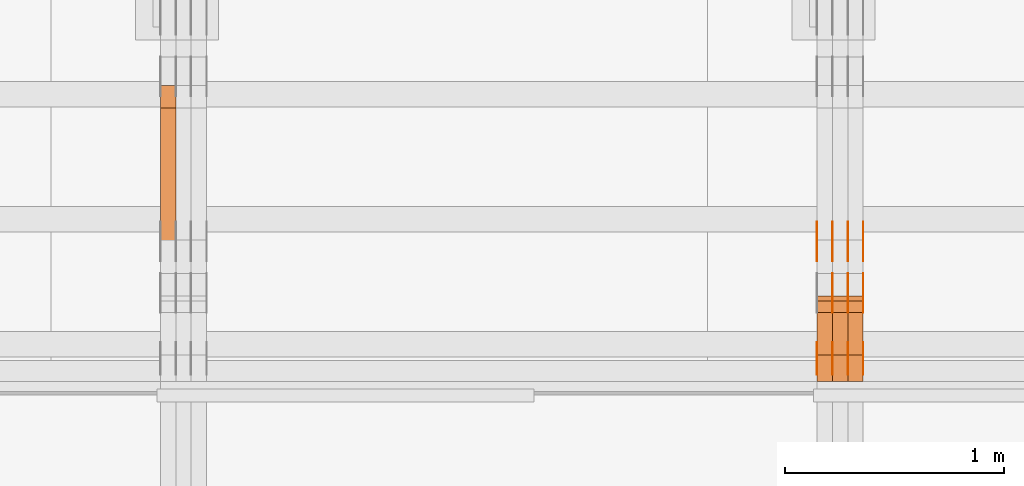
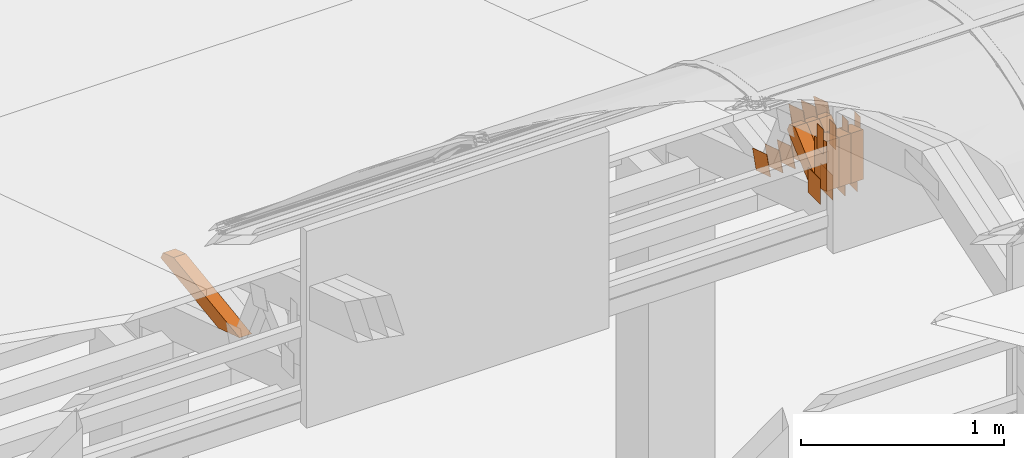
# One storey, part 103 of 385: 30 proxies.
"""IFC2X3 building model written with IfcOpenShell, lengths in millimetres."""

from ifc_helpers import new_model, entity, si_unit, converted_unit, derived_unit, direction, frame, origin, origin_2d_with_axis, place, context, subcontext, project, spatial, polyline, rectangle, outline, extrude, source, transform, mapped, material, type_object, type_shapes, element, save


model = new_model("IFC2X3")

# Units and contexts
model_context = context("Model", 3, precision=0.01, world=origin(), true_north=direction((6.12303176911189e-17, 1.0)))
body_context = subcontext(model_context, "Body", "Model", "MODEL_VIEW")
ifc_project = project(units=[si_unit("LENGTHUNIT", "METRE", prefix="MILLI"), si_unit("AREAUNIT", "SQUARE_METRE"), si_unit("VOLUMEUNIT", "CUBIC_METRE"), converted_unit("PLANEANGLEUNIT", "DEGREE", entity("IfcRatioMeasure", 0.0174532925199433), si_unit("PLANEANGLEUNIT", "RADIAN"), dimensions=[0, 0, 0, 0, 0, 0, 0]), si_unit("MASSUNIT", "GRAM", prefix="KILO"), derived_unit("MASSDENSITYUNIT", [(si_unit("MASSUNIT", "GRAM", prefix="KILO"), 1), (si_unit("LENGTHUNIT", "METRE"), -3)]), si_unit("TIMEUNIT", "SECOND"), si_unit("FREQUENCYUNIT", "HERTZ"), si_unit("THERMODYNAMICTEMPERATUREUNIT", "DEGREE_CELSIUS"), derived_unit("THERMALTRANSMITTANCEUNIT", [(si_unit("MASSUNIT", "GRAM", prefix="KILO"), 1), (si_unit("THERMODYNAMICTEMPERATUREUNIT", "KELVIN"), -1), (si_unit("TIMEUNIT", "SECOND"), -3)]), derived_unit("VOLUMETRICFLOWRATEUNIT", [(si_unit("LENGTHUNIT", "METRE"), 3), (si_unit("TIMEUNIT", "SECOND"), -1)]), si_unit("ELECTRICCURRENTUNIT", "AMPERE"), si_unit("ELECTRICVOLTAGEUNIT", "VOLT"), si_unit("POWERUNIT", "WATT"), si_unit("FORCEUNIT", "NEWTON", prefix="KILO"), si_unit("ILLUMINANCEUNIT", "LUX"), si_unit("LUMINOUSFLUXUNIT", "LUMEN"), si_unit("LUMINOUSINTENSITYUNIT", "CANDELA"), derived_unit("USERDEFINED", [(si_unit("MASSUNIT", "GRAM", prefix="KILO"), -1), (si_unit("LENGTHUNIT", "METRE"), -2), (si_unit("TIMEUNIT", "SECOND"), 3), (si_unit("LUMINOUSFLUXUNIT", "LUMEN"), 1)]), derived_unit("LINEARVELOCITYUNIT", [(si_unit("LENGTHUNIT", "METRE"), 1), (si_unit("TIMEUNIT", "SECOND"), -1)]), si_unit("PRESSUREUNIT", "PASCAL"), derived_unit("USERDEFINED", [(si_unit("LENGTHUNIT", "METRE"), -2), (si_unit("MASSUNIT", "GRAM", prefix="KILO"), 1), (si_unit("TIMEUNIT", "SECOND"), -2)])], contexts=[model_context])

# Site, building, storey
site_placement = place(None, origin())
site = spatial("IfcSite", under=ifc_project, at=site_placement, CompositionType="ELEMENT")
building_placement = place(site_placement, origin())
building = spatial("IfcBuilding", under=site, at=building_placement, CompositionType="ELEMENT")
storey_placement = place(building_placement, origin())
storey = spatial("IfcBuildingStorey", under=building, at=storey_placement, Name="Default", CompositionType="ELEMENT", Elevation=0.0)

# Proxies
ifc_material_1 = material(Name="IfcSurfaceStyle #205378")
building_element_proxy_type_1 = type_object("IfcBuildingElementProxyType", PredefinedType="NOTDEFINED", material=ifc_material_1)
shared_shape_1 = source(origin(), body_context, "Body", "SweptSolid", [
    extrude(rectangle(XDim=150.0, YDim=120.0, at=origin_2d_with_axis()), frame((75.0, 60.0, 0.0), z_axis=(0.0, 0.0, 1.0), x_axis=(-1.0, 0.0, 0.0)), (0.0, 0.0, 1.0), 1.3),
])
type_shapes(building_element_proxy_type_1, [shared_shape_1])
proxy_1_placement = place(building_placement, frame((15386.3, 15840.0, 3652.70166015625), z_axis=(-1.0, 0.0, 0.0), x_axis=(0.0, 0.0, -1.0)))
element("IfcBuildingElementProxy", 1, at=proxy_1_placement, inside=storey, type_object=building_element_proxy_type_1, material=ifc_material_1, context=body_context, shape_type="MappedRepresentation", body=[
    mapped(shared_shape_1, transform((0.0, 0.0, 0.0), scale=1.0)),
])
ifc_material_2 = material(Name="IfcSurfaceStyle #205321")
building_element_proxy_type_2 = type_object("IfcBuildingElementProxyType", PredefinedType="NOTDEFINED", material=ifc_material_2)
shared_shape_2 = source(origin(), body_context, "Body", "SweptSolid", [
    extrude(rectangle(XDim=150.0, YDim=120.0, at=origin_2d_with_axis()), frame((75.0, 60.0, 0.0), z_axis=(0.0, 0.0, 1.0), x_axis=(-1.0, 0.0, 0.0)), (0.0, 0.0, 1.0), 1.3),
])
type_shapes(building_element_proxy_type_2, [shared_shape_2])
proxy_2_placement = place(building_placement, frame((15315.0, 15840.0, 3652.70166015625), z_axis=(-1.0, 0.0, 0.0), x_axis=(0.0, 0.0, -1.0)))
element("IfcBuildingElementProxy", 2, at=proxy_2_placement, inside=storey, type_object=building_element_proxy_type_2, material=ifc_material_2, context=body_context, shape_type="MappedRepresentation", body=[
    mapped(shared_shape_2, transform((0.0, 0.0, 0.0), scale=1.0)),
])
ifc_material_3 = material(Name="IfcSurfaceStyle #205264")
building_element_proxy_type_3 = type_object("IfcBuildingElementProxyType", PredefinedType="NOTDEFINED", material=ifc_material_3)
shared_shape_3 = source(origin(), body_context, "Body", "SweptSolid", [
    extrude(rectangle(XDim=150.0, YDim=120.0, at=origin_2d_with_axis()), frame((75.0, 60.0, 0.0), z_axis=(0.0, 0.0, 1.0), x_axis=(-1.0, 0.0, 0.0)), (0.0, 0.0, 1.0), 1.3),
])
type_shapes(building_element_proxy_type_3, [shared_shape_3])
proxy_3_placement = place(building_placement, frame((15316.3, 15840.0, 3652.70166015625), z_axis=(-1.0, 0.0, 0.0), x_axis=(0.0, 0.0, -1.0)))
element("IfcBuildingElementProxy", 3, at=proxy_3_placement, inside=storey, type_object=building_element_proxy_type_3, material=ifc_material_3, context=body_context, shape_type="MappedRepresentation", body=[
    mapped(shared_shape_3, transform((0.0, 0.0, 0.0), scale=1.0)),
])
ifc_material_4 = material(Name="IfcSurfaceStyle #205207")
building_element_proxy_type_4 = type_object("IfcBuildingElementProxyType", PredefinedType="NOTDEFINED", material=ifc_material_4)
shared_shape_4 = source(origin(), body_context, "Body", "SweptSolid", [
    extrude(rectangle(XDim=150.0, YDim=120.0, at=origin_2d_with_axis()), frame((75.0, 60.0, 0.0), z_axis=(0.0, 0.0, 1.0), x_axis=(-1.0, 0.0, 0.0)), (0.0, 0.0, 1.0), 1.29999999999999),
])
type_shapes(building_element_proxy_type_4, [shared_shape_4])
proxy_4_placement = place(building_placement, frame((15245.0, 15840.0, 3652.70166015625), z_axis=(-1.0, 0.0, 0.0), x_axis=(0.0, 0.0, -1.0)))
element("IfcBuildingElementProxy", 4, at=proxy_4_placement, inside=storey, type_object=building_element_proxy_type_4, material=ifc_material_4, context=body_context, shape_type="MappedRepresentation", body=[
    mapped(shared_shape_4, transform((0.0, 0.0, 0.0), scale=1.0)),
])
ifc_material_5 = material(Name="IfcSurfaceStyle #205150")
building_element_proxy_type_5 = type_object("IfcBuildingElementProxyType", PredefinedType="NOTDEFINED", material=ifc_material_5)
shared_shape_5 = source(origin(), body_context, "Body", "SweptSolid", [
    extrude(rectangle(XDim=150.0, YDim=120.0, at=origin_2d_with_axis()), frame((75.0, 60.0, 0.0), z_axis=(0.0, 0.0, 1.0), x_axis=(-1.0, 0.0, 0.0)), (0.0, 0.0, 1.0), 1.29999999999999),
])
type_shapes(building_element_proxy_type_5, [shared_shape_5])
proxy_5_placement = place(building_placement, frame((15246.3, 15840.0, 3652.70166015625), z_axis=(-1.0, 0.0, 0.0), x_axis=(0.0, 0.0, -1.0)))
element("IfcBuildingElementProxy", 5, at=proxy_5_placement, inside=storey, type_object=building_element_proxy_type_5, material=ifc_material_5, context=body_context, shape_type="MappedRepresentation", body=[
    mapped(shared_shape_5, transform((0.0, 0.0, 0.0), scale=1.0)),
])
ifc_material_6 = material(Name="IfcSurfaceStyle #205093")
building_element_proxy_type_6 = type_object("IfcBuildingElementProxyType", PredefinedType="NOTDEFINED", material=ifc_material_6)
shared_shape_6 = source(origin(), body_context, "Body", "SweptSolid", [
    extrude(rectangle(XDim=150.0, YDim=120.0, at=origin_2d_with_axis()), frame((75.0, 60.0, 0.0), z_axis=(0.0, 0.0, 1.0), x_axis=(-1.0, 0.0, 0.0)), (0.0, 0.0, 1.0), 1.29999999999999),
])
type_shapes(building_element_proxy_type_6, [shared_shape_6])
proxy_6_placement = place(building_placement, frame((15175.0, 15840.0, 3652.70166015625), z_axis=(-1.0, 0.0, 0.0), x_axis=(0.0, 0.0, -1.0)))
element("IfcBuildingElementProxy", 6, at=proxy_6_placement, inside=storey, type_object=building_element_proxy_type_6, material=ifc_material_6, context=body_context, shape_type="MappedRepresentation", body=[
    mapped(shared_shape_6, transform((0.0, 0.0, 0.0), scale=1.0)),
])
ifc_material_7 = material(Name="IfcSurfaceStyle #205036")
building_element_proxy_type_7 = type_object("IfcBuildingElementProxyType", PredefinedType="NOTDEFINED", material=ifc_material_7)
shared_shape_7 = source(origin(), body_context, "Body", "SweptSolid", [
    extrude(outline(polyline([(-74.9998605591118, -59.9999264677601), (74.9998754286171, -59.9999264677601), (74.9998605591118, 59.9999264677602), (-74.9998754286171, 59.9999264677602), (-74.9998605591118, -59.9999264677601)])), frame((74.9998754286171, 60.0000503992849, 0.0), z_axis=(0.0, 0.0, 1.0), x_axis=(-1.0, 0.0, 0.0)), (0.0, 0.0, 1.0), 1.3),
])
type_shapes(building_element_proxy_type_7, [shared_shape_7])
proxy_7_placement = place(building_placement, frame((15386.3, 16352.8320303235, 3323.23212676408), z_axis=(-1.0, 0.0, 0.0), x_axis=(0.0, -0.951056516295124, 0.309016994375039)))
element("IfcBuildingElementProxy", 7, at=proxy_7_placement, inside=storey, type_object=building_element_proxy_type_7, material=ifc_material_7, context=body_context, shape_type="MappedRepresentation", body=[
    mapped(shared_shape_7, transform((0.0, 0.0, 0.0), scale=1.0)),
])
ifc_material_8 = material(Name="IfcSurfaceStyle #204979")
building_element_proxy_type_8 = type_object("IfcBuildingElementProxyType", PredefinedType="NOTDEFINED", material=ifc_material_8)
shared_shape_8 = source(origin(), body_context, "Body", "SweptSolid", [
    extrude(outline(polyline([(-74.9998605591118, -59.9999264677601), (74.9998754286171, -59.9999264677601), (74.9998605591118, 59.9999264677602), (-74.9998754286171, 59.9999264677602), (-74.9998605591118, -59.9999264677601)])), frame((74.9998754286171, 60.0000503992849, 0.0), z_axis=(0.0, 0.0, 1.0), x_axis=(-1.0, 0.0, 0.0)), (0.0, 0.0, 1.0), 1.3),
])
type_shapes(building_element_proxy_type_8, [shared_shape_8])
proxy_8_placement = place(building_placement, frame((15315.0, 16352.8320303235, 3323.23212676408), z_axis=(-1.0, 0.0, 0.0), x_axis=(0.0, -0.951056516295124, 0.309016994375039)))
element("IfcBuildingElementProxy", 8, at=proxy_8_placement, inside=storey, type_object=building_element_proxy_type_8, material=ifc_material_8, context=body_context, shape_type="MappedRepresentation", body=[
    mapped(shared_shape_8, transform((0.0, 0.0, 0.0), scale=1.0)),
])
ifc_material_9 = material(Name="IfcSurfaceStyle #204922")
building_element_proxy_type_9 = type_object("IfcBuildingElementProxyType", PredefinedType="NOTDEFINED", material=ifc_material_9)
shared_shape_9 = source(origin(), body_context, "Body", "SweptSolid", [
    extrude(outline(polyline([(-74.9998605591118, -59.9999264677601), (74.9998754286171, -59.9999264677601), (74.9998605591118, 59.9999264677602), (-74.9998754286171, 59.9999264677602), (-74.9998605591118, -59.9999264677601)])), frame((74.9998754286171, 60.0000503992849, 0.0), z_axis=(0.0, 0.0, 1.0), x_axis=(-1.0, 0.0, 0.0)), (0.0, 0.0, 1.0), 1.3),
])
type_shapes(building_element_proxy_type_9, [shared_shape_9])
proxy_9_placement = place(building_placement, frame((15316.3, 16352.8320303235, 3323.23212676408), z_axis=(-1.0, 0.0, 0.0), x_axis=(0.0, -0.951056516295124, 0.309016994375039)))
element("IfcBuildingElementProxy", 9, at=proxy_9_placement, inside=storey, type_object=building_element_proxy_type_9, material=ifc_material_9, context=body_context, shape_type="MappedRepresentation", body=[
    mapped(shared_shape_9, transform((0.0, 0.0, 0.0), scale=1.0)),
])
ifc_material_10 = material(Name="IfcSurfaceStyle #204865")
building_element_proxy_type_10 = type_object("IfcBuildingElementProxyType", PredefinedType="NOTDEFINED", material=ifc_material_10)
shared_shape_10 = source(origin(), body_context, "Body", "SweptSolid", [
    extrude(outline(polyline([(-74.9998605591118, -59.9999264677601), (74.9998754286171, -59.9999264677601), (74.9998605591118, 59.9999264677602), (-74.9998754286171, 59.9999264677602), (-74.9998605591118, -59.9999264677601)])), frame((74.9998754286171, 60.0000503992849, 0.0), z_axis=(0.0, 0.0, 1.0), x_axis=(-1.0, 0.0, 0.0)), (0.0, 0.0, 1.0), 1.29999999999999),
])
type_shapes(building_element_proxy_type_10, [shared_shape_10])
proxy_10_placement = place(building_placement, frame((15245.0, 16352.8320303235, 3323.23212676408), z_axis=(-1.0, 0.0, 0.0), x_axis=(0.0, -0.951056516295124, 0.309016994375039)))
element("IfcBuildingElementProxy", 10, at=proxy_10_placement, inside=storey, type_object=building_element_proxy_type_10, material=ifc_material_10, context=body_context, shape_type="MappedRepresentation", body=[
    mapped(shared_shape_10, transform((0.0, 0.0, 0.0), scale=1.0)),
])
ifc_material_11 = material(Name="IfcSurfaceStyle #204808")
building_element_proxy_type_11 = type_object("IfcBuildingElementProxyType", PredefinedType="NOTDEFINED", material=ifc_material_11)
shared_shape_11 = source(origin(), body_context, "Body", "SweptSolid", [
    extrude(outline(polyline([(-74.9998605591118, -59.9999264677601), (74.9998754286171, -59.9999264677601), (74.9998605591118, 59.9999264677602), (-74.9998754286171, 59.9999264677602), (-74.9998605591118, -59.9999264677601)])), frame((74.9998754286171, 60.0000503992849, 0.0), z_axis=(0.0, 0.0, 1.0), x_axis=(-1.0, 0.0, 0.0)), (0.0, 0.0, 1.0), 1.29999999999999),
])
type_shapes(building_element_proxy_type_11, [shared_shape_11])
proxy_11_placement = place(building_placement, frame((15246.3, 16352.8320303235, 3323.23212676408), z_axis=(-1.0, 0.0, 0.0), x_axis=(0.0, -0.951056516295124, 0.309016994375039)))
element("IfcBuildingElementProxy", 11, at=proxy_11_placement, inside=storey, type_object=building_element_proxy_type_11, material=ifc_material_11, context=body_context, shape_type="MappedRepresentation", body=[
    mapped(shared_shape_11, transform((0.0, 0.0, 0.0), scale=1.0)),
])
ifc_material_12 = material(Name="IfcSurfaceStyle #204751")
building_element_proxy_type_12 = type_object("IfcBuildingElementProxyType", PredefinedType="NOTDEFINED", material=ifc_material_12)
shared_shape_12 = source(origin(), body_context, "Body", "SweptSolid", [
    extrude(outline(polyline([(-74.9998605591118, -59.9999264677601), (74.9998754286171, -59.9999264677601), (74.9998605591118, 59.9999264677602), (-74.9998754286171, 59.9999264677602), (-74.9998605591118, -59.9999264677601)])), frame((74.9998754286171, 60.0000503992849, 0.0), z_axis=(0.0, 0.0, 1.0), x_axis=(-1.0, 0.0, 0.0)), (0.0, 0.0, 1.0), 1.29999999999999),
])
type_shapes(building_element_proxy_type_12, [shared_shape_12])
proxy_12_placement = place(building_placement, frame((15175.0, 16352.8320303235, 3323.23212676408), z_axis=(-1.0, 0.0, 0.0), x_axis=(0.0, -0.951056516295124, 0.309016994375039)))
element("IfcBuildingElementProxy", 12, at=proxy_12_placement, inside=storey, type_object=building_element_proxy_type_12, material=ifc_material_12, context=body_context, shape_type="MappedRepresentation", body=[
    mapped(shared_shape_12, transform((0.0, 0.0, 0.0), scale=1.0)),
])
ifc_material_13 = material(Name="IfcSurfaceStyle #200590")
building_element_proxy_type_13 = type_object("IfcBuildingElementProxyType", PredefinedType="NOTDEFINED", material=ifc_material_13)
shared_shape_13 = source(origin(), body_context, "Body", "SweptSolid", [
    extrude(outline(polyline([(-75.0003249421702, -60.0000773549573), (75.0003398116874, -60.0000773549573), (75.0003249421711, 60.0000773549573), (-75.0003398116883, 60.0000773549573), (-75.0003249421702, -60.0000773549573)])), frame((75.0003398116874, 60.0000773549573, 0.0), z_axis=(0.0, 0.0, 1.0), x_axis=(-1.0, 0.0, 0.0)), (0.0, 0.0, 1.0), 1.3),
])
type_shapes(building_element_proxy_type_13, [shared_shape_13])
proxy_13_placement = place(building_placement, frame((15386.3, 16117.0849050545, 3705.49074668796), z_axis=(-1.0, 0.0, 0.0), x_axis=(0.0, -0.951056516295154, 0.309016994374948)))
element("IfcBuildingElementProxy", 13, at=proxy_13_placement, inside=storey, type_object=building_element_proxy_type_13, material=ifc_material_13, context=body_context, shape_type="MappedRepresentation", body=[
    mapped(shared_shape_13, transform((0.0, 0.0, 0.0), scale=1.0)),
])
ifc_material_14 = material(Name="IfcSurfaceStyle #200533")
building_element_proxy_type_14 = type_object("IfcBuildingElementProxyType", PredefinedType="NOTDEFINED", material=ifc_material_14)
shared_shape_14 = source(origin(), body_context, "Body", "SweptSolid", [
    extrude(outline(polyline([(-75.0003249421702, -60.0000773549573), (75.0003398116874, -60.0000773549573), (75.0003249421711, 60.0000773549573), (-75.0003398116883, 60.0000773549573), (-75.0003249421702, -60.0000773549573)])), frame((75.0003398116874, 60.0000773549573, 0.0), z_axis=(0.0, 0.0, 1.0), x_axis=(-1.0, 0.0, 0.0)), (0.0, 0.0, 1.0), 1.3),
])
type_shapes(building_element_proxy_type_14, [shared_shape_14])
proxy_14_placement = place(building_placement, frame((15315.0, 16117.0849050545, 3705.49074668796), z_axis=(-1.0, 0.0, 0.0), x_axis=(0.0, -0.951056516295154, 0.309016994374948)))
element("IfcBuildingElementProxy", 14, at=proxy_14_placement, inside=storey, type_object=building_element_proxy_type_14, material=ifc_material_14, context=body_context, shape_type="MappedRepresentation", body=[
    mapped(shared_shape_14, transform((0.0, 0.0, 0.0), scale=1.0)),
])
ifc_material_15 = material(Name="IfcSurfaceStyle #200476")
building_element_proxy_type_15 = type_object("IfcBuildingElementProxyType", PredefinedType="NOTDEFINED", material=ifc_material_15)
shared_shape_15 = source(origin(), body_context, "Body", "SweptSolid", [
    extrude(outline(polyline([(-75.0003249421702, -60.0000773549573), (75.0003398116874, -60.0000773549573), (75.0003249421711, 60.0000773549573), (-75.0003398116883, 60.0000773549573), (-75.0003249421702, -60.0000773549573)])), frame((75.0003398116874, 60.0000773549573, 0.0), z_axis=(0.0, 0.0, 1.0), x_axis=(-1.0, 0.0, 0.0)), (0.0, 0.0, 1.0), 1.3),
])
type_shapes(building_element_proxy_type_15, [shared_shape_15])
proxy_15_placement = place(building_placement, frame((15316.3, 16117.0849050545, 3705.49074668796), z_axis=(-1.0, 0.0, 0.0), x_axis=(0.0, -0.951056516295154, 0.309016994374948)))
element("IfcBuildingElementProxy", 15, at=proxy_15_placement, inside=storey, type_object=building_element_proxy_type_15, material=ifc_material_15, context=body_context, shape_type="MappedRepresentation", body=[
    mapped(shared_shape_15, transform((0.0, 0.0, 0.0), scale=1.0)),
])
ifc_material_16 = material(Name="IfcSurfaceStyle #200419")
building_element_proxy_type_16 = type_object("IfcBuildingElementProxyType", PredefinedType="NOTDEFINED", material=ifc_material_16)
shared_shape_16 = source(origin(), body_context, "Body", "SweptSolid", [
    extrude(outline(polyline([(-75.0003249421702, -60.0000773549573), (75.0003398116874, -60.0000773549573), (75.0003249421711, 60.0000773549573), (-75.0003398116883, 60.0000773549573), (-75.0003249421702, -60.0000773549573)])), frame((75.0003398116874, 60.0000773549573, 0.0), z_axis=(0.0, 0.0, 1.0), x_axis=(-1.0, 0.0, 0.0)), (0.0, 0.0, 1.0), 1.29999999999999),
])
type_shapes(building_element_proxy_type_16, [shared_shape_16])
proxy_16_placement = place(building_placement, frame((15245.0, 16117.0849050545, 3705.49074668796), z_axis=(-1.0, 0.0, 0.0), x_axis=(0.0, -0.951056516295154, 0.309016994374948)))
element("IfcBuildingElementProxy", 16, at=proxy_16_placement, inside=storey, type_object=building_element_proxy_type_16, material=ifc_material_16, context=body_context, shape_type="MappedRepresentation", body=[
    mapped(shared_shape_16, transform((0.0, 0.0, 0.0), scale=1.0)),
])
ifc_material_17 = material(Name="IfcSurfaceStyle #200362")
building_element_proxy_type_17 = type_object("IfcBuildingElementProxyType", PredefinedType="NOTDEFINED", material=ifc_material_17)
shared_shape_17 = source(origin(), body_context, "Body", "SweptSolid", [
    extrude(outline(polyline([(-75.0003249421702, -60.0000773549573), (75.0003398116874, -60.0000773549573), (75.0003249421711, 60.0000773549573), (-75.0003398116883, 60.0000773549573), (-75.0003249421702, -60.0000773549573)])), frame((75.0003398116874, 60.0000773549573, 0.0), z_axis=(0.0, 0.0, 1.0), x_axis=(-1.0, 0.0, 0.0)), (0.0, 0.0, 1.0), 1.29999999999999),
])
type_shapes(building_element_proxy_type_17, [shared_shape_17])
proxy_17_placement = place(building_placement, frame((15246.3, 16117.0849050545, 3705.49074668796), z_axis=(-1.0, 0.0, 0.0), x_axis=(0.0, -0.951056516295154, 0.309016994374948)))
element("IfcBuildingElementProxy", 17, at=proxy_17_placement, inside=storey, type_object=building_element_proxy_type_17, material=ifc_material_17, context=body_context, shape_type="MappedRepresentation", body=[
    mapped(shared_shape_17, transform((0.0, 0.0, 0.0), scale=1.0)),
])
ifc_material_18 = material(Name="IfcSurfaceStyle #199906")
building_element_proxy_type_18 = type_object("IfcBuildingElementProxyType", PredefinedType="NOTDEFINED", material=ifc_material_18)
shared_shape_18 = source(origin(), body_context, "Body", "SweptSolid", [
    extrude(rectangle(XDim=150.0, YDim=60.0, at=origin_2d_with_axis()), frame((75.0000705696311, 30.0, 0.0), z_axis=(0.0, 0.0, 1.0), x_axis=(-1.0, 0.0, 0.0)), (0.0, 0.0, 1.0), 1.3),
])
type_shapes(building_element_proxy_type_18, [shared_shape_18])
proxy_18_placement = place(building_placement, frame((15386.3, 15750.0, 3972.59919166338), z_axis=(-1.0, 0.0, 0.0), x_axis=(0.0, 0.0, -1.0)))
element("IfcBuildingElementProxy", 18, at=proxy_18_placement, inside=storey, type_object=building_element_proxy_type_18, material=ifc_material_18, context=body_context, shape_type="MappedRepresentation", body=[
    mapped(shared_shape_18, transform((0.0, 0.0, 0.0), scale=1.0)),
])
ifc_material_19 = material(Name="IfcSurfaceStyle #199849")
building_element_proxy_type_19 = type_object("IfcBuildingElementProxyType", PredefinedType="NOTDEFINED", material=ifc_material_19)
shared_shape_19 = source(origin(), body_context, "Body", "SweptSolid", [
    extrude(rectangle(XDim=150.0, YDim=60.0, at=origin_2d_with_axis()), frame((75.0000705696311, 30.0, 0.0), z_axis=(0.0, 0.0, 1.0), x_axis=(-1.0, 0.0, 0.0)), (0.0, 0.0, 1.0), 1.3),
])
type_shapes(building_element_proxy_type_19, [shared_shape_19])
proxy_19_placement = place(building_placement, frame((15315.0, 15750.0, 3972.59919166338), z_axis=(-1.0, 0.0, 0.0), x_axis=(0.0, 0.0, -1.0)))
element("IfcBuildingElementProxy", 19, at=proxy_19_placement, inside=storey, type_object=building_element_proxy_type_19, material=ifc_material_19, context=body_context, shape_type="MappedRepresentation", body=[
    mapped(shared_shape_19, transform((0.0, 0.0, 0.0), scale=1.0)),
])
ifc_material_20 = material(Name="IfcSurfaceStyle #199792")
building_element_proxy_type_20 = type_object("IfcBuildingElementProxyType", PredefinedType="NOTDEFINED", material=ifc_material_20)
shared_shape_20 = source(origin(), body_context, "Body", "SweptSolid", [
    extrude(rectangle(XDim=150.0, YDim=60.0, at=origin_2d_with_axis()), frame((75.0000705696311, 30.0, 0.0), z_axis=(0.0, 0.0, 1.0), x_axis=(-1.0, 0.0, 0.0)), (0.0, 0.0, 1.0), 1.3),
])
type_shapes(building_element_proxy_type_20, [shared_shape_20])
proxy_20_placement = place(building_placement, frame((15316.3, 15750.0, 3972.59919166338), z_axis=(-1.0, 0.0, 0.0), x_axis=(0.0, 0.0, -1.0)))
element("IfcBuildingElementProxy", 20, at=proxy_20_placement, inside=storey, type_object=building_element_proxy_type_20, material=ifc_material_20, context=body_context, shape_type="MappedRepresentation", body=[
    mapped(shared_shape_20, transform((0.0, 0.0, 0.0), scale=1.0)),
])
ifc_material_21 = material(Name="IfcSurfaceStyle #199735")
building_element_proxy_type_21 = type_object("IfcBuildingElementProxyType", PredefinedType="NOTDEFINED", material=ifc_material_21)
shared_shape_21 = source(origin(), body_context, "Body", "SweptSolid", [
    extrude(rectangle(XDim=150.0, YDim=60.0, at=origin_2d_with_axis()), frame((75.0000705696311, 30.0, 0.0), z_axis=(0.0, 0.0, 1.0), x_axis=(-1.0, 0.0, 0.0)), (0.0, 0.0, 1.0), 1.29999999999999),
])
type_shapes(building_element_proxy_type_21, [shared_shape_21])
proxy_21_placement = place(building_placement, frame((15245.0, 15750.0, 3972.59919166338), z_axis=(-1.0, 0.0, 0.0), x_axis=(0.0, 0.0, -1.0)))
element("IfcBuildingElementProxy", 21, at=proxy_21_placement, inside=storey, type_object=building_element_proxy_type_21, material=ifc_material_21, context=body_context, shape_type="MappedRepresentation", body=[
    mapped(shared_shape_21, transform((0.0, 0.0, 0.0), scale=1.0)),
])
ifc_material_22 = material(Name="IfcSurfaceStyle #199678")
building_element_proxy_type_22 = type_object("IfcBuildingElementProxyType", PredefinedType="NOTDEFINED", material=ifc_material_22)
shared_shape_22 = source(origin(), body_context, "Body", "SweptSolid", [
    extrude(rectangle(XDim=150.0, YDim=60.0, at=origin_2d_with_axis()), frame((75.0000705696311, 30.0, 0.0), z_axis=(0.0, 0.0, 1.0), x_axis=(-1.0, 0.0, 0.0)), (0.0, 0.0, 1.0), 1.29999999999999),
])
type_shapes(building_element_proxy_type_22, [shared_shape_22])
proxy_22_placement = place(building_placement, frame((15246.3, 15750.0, 3972.59919166338), z_axis=(-1.0, 0.0, 0.0), x_axis=(0.0, 0.0, -1.0)))
element("IfcBuildingElementProxy", 22, at=proxy_22_placement, inside=storey, type_object=building_element_proxy_type_22, material=ifc_material_22, context=body_context, shape_type="MappedRepresentation", body=[
    mapped(shared_shape_22, transform((0.0, 0.0, 0.0), scale=1.0)),
])
ifc_material_23 = material(Name="IfcSurfaceStyle #199621")
building_element_proxy_type_23 = type_object("IfcBuildingElementProxyType", PredefinedType="NOTDEFINED", material=ifc_material_23)
shared_shape_23 = source(origin(), body_context, "Body", "SweptSolid", [
    extrude(rectangle(XDim=150.0, YDim=60.0, at=origin_2d_with_axis()), frame((75.0000705696311, 30.0, 0.0), z_axis=(0.0, 0.0, 1.0), x_axis=(-1.0, 0.0, 0.0)), (0.0, 0.0, 1.0), 1.29999999999999),
])
type_shapes(building_element_proxy_type_23, [shared_shape_23])
proxy_23_placement = place(building_placement, frame((15175.0, 15750.0, 3972.59919166338), z_axis=(-1.0, 0.0, 0.0), x_axis=(0.0, 0.0, -1.0)))
element("IfcBuildingElementProxy", 23, at=proxy_23_placement, inside=storey, type_object=building_element_proxy_type_23, material=ifc_material_23, context=body_context, shape_type="MappedRepresentation", body=[
    mapped(shared_shape_23, transform((0.0, 0.0, 0.0), scale=1.0)),
])
ifc_material_24 = material(Name="IfcSurfaceStyle #190537")
building_element_proxy_type_24 = type_object("IfcBuildingElementProxyType", Name="T1-W50 190535", PredefinedType="NOTDEFINED", material=ifc_material_24)
shared_shape_24 = source(origin(), body_context, "Body", "SweptSolid", [
    extrude(outline(polyline([(-128.56619634284, -47.4999385885712), (133.151257249084, -47.4999385885712), (161.172800006526, -0.000129729183733609), (147.291467726413, 47.500068317755), (-142.513973767368, 47.500068317755), (-170.535354871815, -0.000129729183754689), (-128.56619634284, -47.4999385885712)])), frame((161.17310141218, 47.5001898716564, 0.0), z_axis=(0.0, 0.0, 1.0), x_axis=(-1.0, 0.0, 0.0)), (0.0, 0.0, 1.0), 70.0),
])
type_shapes(building_element_proxy_type_24, [shared_shape_24])
proxy_24_placement = place(building_placement, frame((15385.0, 16060.0297689714, 3761.73994820667), z_axis=(-1.0, 0.0, 0.0), x_axis=(0.0, -0.749388407538668, -0.662130662820156)))
element("IfcBuildingElementProxy", 24, at=proxy_24_placement, inside=storey, type_object=building_element_proxy_type_24, material=ifc_material_24, Name="T1-W50", context=body_context, shape_type="MappedRepresentation", body=[
    mapped(shared_shape_24, transform((0.0, 0.0, 0.0), scale=1.0)),
])
ifc_material_25 = material(Name="IfcSurfaceStyle #190462")
building_element_proxy_type_25 = type_object("IfcBuildingElementProxyType", Name="T1-W50 190460", PredefinedType="NOTDEFINED", material=ifc_material_25)
shared_shape_25 = source(origin(), body_context, "Body", "SweptSolid", [
    extrude(outline(polyline([(-128.56619634284, -47.4999385885712), (133.151257249084, -47.4999385885712), (161.172800006526, -0.000129729183733609), (147.291467726413, 47.500068317755), (-142.513973767368, 47.500068317755), (-170.535354871815, -0.000129729183754689), (-128.56619634284, -47.4999385885712)])), frame((161.17310141218, 47.5001898716564, 0.0), z_axis=(0.0, 0.0, 1.0), x_axis=(-1.0, 0.0, 0.0)), (0.0, 0.0, 1.0), 70.0),
])
type_shapes(building_element_proxy_type_25, [shared_shape_25])
proxy_25_placement = place(building_placement, frame((15315.0, 16060.0297689714, 3761.73994820667), z_axis=(-1.0, 0.0, 0.0), x_axis=(0.0, -0.749388407538668, -0.662130662820156)))
element("IfcBuildingElementProxy", 25, at=proxy_25_placement, inside=storey, type_object=building_element_proxy_type_25, material=ifc_material_25, Name="T1-W50", context=body_context, shape_type="MappedRepresentation", body=[
    mapped(shared_shape_25, transform((0.0, 0.0, 0.0), scale=1.0)),
])
ifc_material_26 = material(Name="IfcSurfaceStyle #190387")
building_element_proxy_type_26 = type_object("IfcBuildingElementProxyType", Name="T1-W50 190385", PredefinedType="NOTDEFINED", material=ifc_material_26)
shared_shape_26 = source(origin(), body_context, "Body", "SweptSolid", [
    extrude(outline(polyline([(-128.56619634284, -47.4999385885712), (133.151257249084, -47.4999385885712), (161.172800006526, -0.000129729183733609), (147.291467726413, 47.500068317755), (-142.513973767368, 47.500068317755), (-170.535354871815, -0.000129729183754689), (-128.56619634284, -47.4999385885712)])), frame((161.17310141218, 47.5001898716564, 0.0), z_axis=(0.0, 0.0, 1.0), x_axis=(-1.0, 0.0, 0.0)), (0.0, 0.0, 1.0), 70.0),
])
type_shapes(building_element_proxy_type_26, [shared_shape_26])
proxy_26_placement = place(building_placement, frame((15245.0, 16060.0297689714, 3761.73994820667), z_axis=(-1.0, 0.0, 0.0), x_axis=(0.0, -0.749388407538668, -0.662130662820156)))
element("IfcBuildingElementProxy", 26, at=proxy_26_placement, inside=storey, type_object=building_element_proxy_type_26, material=ifc_material_26, Name="T1-W50", context=body_context, shape_type="MappedRepresentation", body=[
    mapped(shared_shape_26, transform((0.0, 0.0, 0.0), scale=1.0)),
])
ifc_material_27 = material(Name="IfcSurfaceStyle #190141")
building_element_proxy_type_27 = type_object("IfcBuildingElementProxyType", Name="T1-W2 190139", PredefinedType="NOTDEFINED", material=ifc_material_27)
shared_shape_27 = source(origin(), body_context, "Body", "SweptSolid", [
    extrude(outline(polyline([(-130.705993652344, -60.0), (169.696350097656, -60.0), (130.706115722656, 60.0), (-169.696472167969, 60.0), (-130.705993652344, -60.0)])), frame((169.696429629256, 60.0, 0.0), z_axis=(0.0, 0.0, 1.0), x_axis=(-1.0, 0.0, 0.0)), (0.0, 0.0, 1.0), 70.0),
])
type_shapes(building_element_proxy_type_27, [shared_shape_27])
proxy_27_placement = place(building_placement, frame((15385.0, 15660.0, 3577.70158062465), z_axis=(-1.0, 0.0, 0.0), x_axis=(0.0, 0.0, 1.0)))
element("IfcBuildingElementProxy", 27, at=proxy_27_placement, inside=storey, type_object=building_element_proxy_type_27, material=ifc_material_27, Name="T1-W2", context=body_context, shape_type="MappedRepresentation", body=[
    mapped(shared_shape_27, transform((0.0, 0.0, 0.0), scale=1.0)),
])
ifc_material_28 = material(Name="IfcSurfaceStyle #190084")
building_element_proxy_type_28 = type_object("IfcBuildingElementProxyType", Name="T1-W2 190082", PredefinedType="NOTDEFINED", material=ifc_material_28)
shared_shape_28 = source(origin(), body_context, "Body", "SweptSolid", [
    extrude(outline(polyline([(-130.705993652344, -60.0), (169.696350097656, -60.0), (130.706115722656, 60.0), (-169.696472167969, 60.0), (-130.705993652344, -60.0)])), frame((169.696429629256, 60.0, 0.0), z_axis=(0.0, 0.0, 1.0), x_axis=(-1.0, 0.0, 0.0)), (0.0, 0.0, 1.0), 70.0),
])
type_shapes(building_element_proxy_type_28, [shared_shape_28])
proxy_28_placement = place(building_placement, frame((15315.0, 15660.0, 3577.70158062465), z_axis=(-1.0, 0.0, 0.0), x_axis=(0.0, 0.0, 1.0)))
element("IfcBuildingElementProxy", 28, at=proxy_28_placement, inside=storey, type_object=building_element_proxy_type_28, material=ifc_material_28, Name="T1-W2", context=body_context, shape_type="MappedRepresentation", body=[
    mapped(shared_shape_28, transform((0.0, 0.0, 0.0), scale=1.0)),
])
ifc_material_29 = material(Name="IfcSurfaceStyle #190027")
building_element_proxy_type_29 = type_object("IfcBuildingElementProxyType", Name="T1-W2 190025", PredefinedType="NOTDEFINED", material=ifc_material_29)
shared_shape_29 = source(origin(), body_context, "Body", "SweptSolid", [
    extrude(outline(polyline([(-130.705993652344, -60.0), (169.696350097656, -60.0), (130.706115722656, 60.0), (-169.696472167969, 60.0), (-130.705993652344, -60.0)])), frame((169.696429629256, 60.0, 0.0), z_axis=(0.0, 0.0, 1.0), x_axis=(-1.0, 0.0, 0.0)), (0.0, 0.0, 1.0), 70.0),
])
type_shapes(building_element_proxy_type_29, [shared_shape_29])
proxy_29_placement = place(building_placement, frame((15245.0, 15660.0, 3577.70158062465), z_axis=(-1.0, 0.0, 0.0), x_axis=(0.0, 0.0, 1.0)))
element("IfcBuildingElementProxy", 29, at=proxy_29_placement, inside=storey, type_object=building_element_proxy_type_29, material=ifc_material_29, Name="T1-W2", context=body_context, shape_type="MappedRepresentation", body=[
    mapped(shared_shape_29, transform((0.0, 0.0, 0.0), scale=1.0)),
])
ifc_material_30 = material(Name="IfcSurfaceStyle #155010")
building_element_proxy_type_30 = type_object("IfcBuildingElementProxyType", Name="T1-W8 155008", PredefinedType="NOTDEFINED", material=ifc_material_30)
shared_shape_30 = source(origin(), body_context, "Body", "SweptSolid", [
    extrude(outline(polyline([(-476.725263324644, -47.5001051695965), (180.672765845439, -47.5001051695965), (279.11020091716, -1.03605560390907e-06), (296.793624402619, 47.5001056876243), (-279.851327840575, 47.5001056876243), (-476.725263324644, -47.5001051695965)])), frame((296.793624402619, 47.5001056876243, 0.0), z_axis=(0.0, 0.0, 1.0), x_axis=(-1.0, 0.0, 0.0)), (0.0, 0.0, 1.0), 70.0),
])
type_shapes(building_element_proxy_type_30, [shared_shape_30])
proxy_30_placement = place(building_placement, frame((12245.0, 17036.40625, 3432.97192382813), z_axis=(-1.0, 0.0, 0.0), x_axis=(0.0, -0.990844046556832, -0.135011389900564)))
element("IfcBuildingElementProxy", 30, at=proxy_30_placement, inside=storey, type_object=building_element_proxy_type_30, material=ifc_material_30, Name="T1-W8", context=body_context, shape_type="MappedRepresentation", body=[
    mapped(shared_shape_30, transform((0.0, 0.0, 0.0), scale=1.0)),
])

save(model, "model.ifc")
